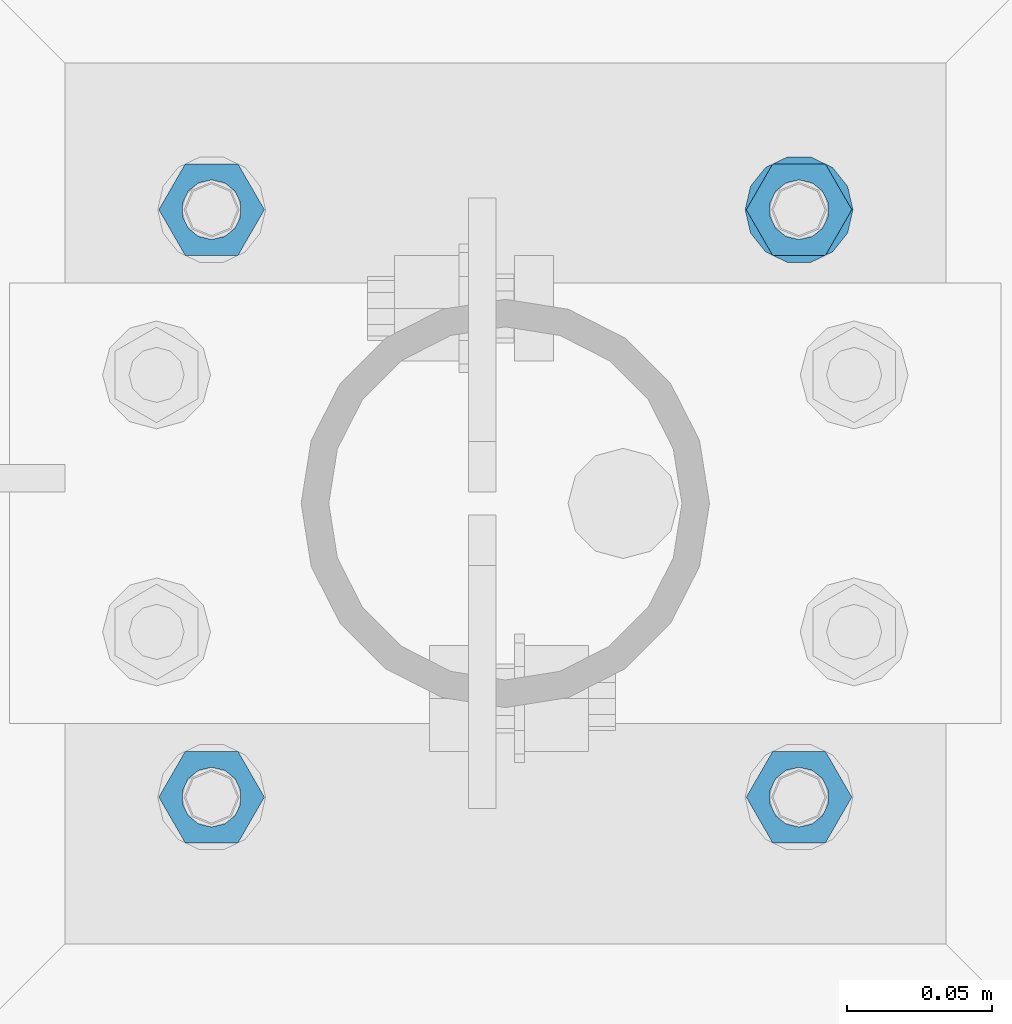
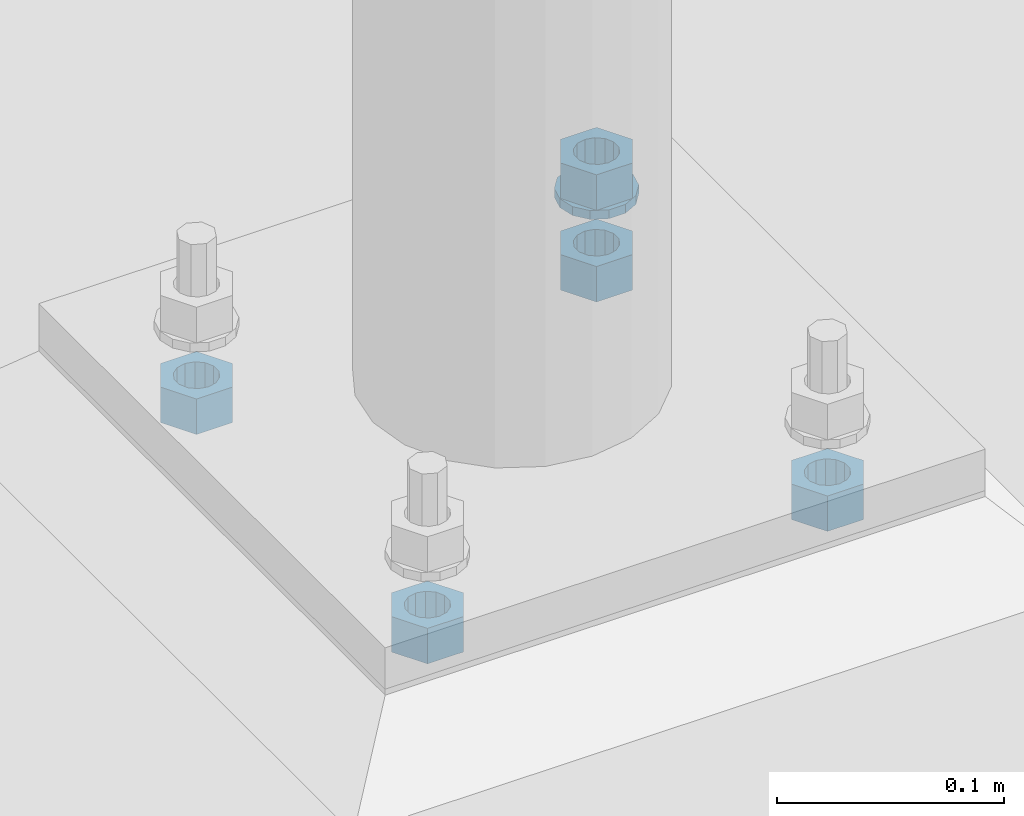
# One storey, part 564 of 975: 6 beams.
"""IFC2X3 building model written with IfcOpenShell, lengths in millimetres."""

from ifc_helpers import new_model, si_unit, frame, origin_with_axes, place, context, subcontext, project, spatial, faceted_brep, material, type_object, element, save


model = new_model("IFC2X3")

# Units and contexts
model_context = context("Model", 3, precision=1e-05, world=origin_with_axes())
body_context = subcontext(model_context, "Body", "Model", "MODEL_VIEW")
ifc_project = project(units=[si_unit("LENGTHUNIT", "METRE", prefix="MILLI"), si_unit("AREAUNIT", "SQUARE_METRE"), si_unit("VOLUMEUNIT", "CUBIC_METRE"), si_unit("MASSUNIT", "GRAM", prefix="KILO"), si_unit("TIMEUNIT", "SECOND"), si_unit("PLANEANGLEUNIT", "RADIAN"), si_unit("SOLIDANGLEUNIT", "STERADIAN"), si_unit("THERMODYNAMICTEMPERATUREUNIT", "DEGREE_CELSIUS"), si_unit("LUMINOUSINTENSITYUNIT", "LUMEN")], contexts=[model_context])

# Site, building, storey
site_placement = place(None, origin_with_axes())
site = spatial("IfcSite", under=ifc_project, at=site_placement, CompositionType="ELEMENT")
building_placement = place(site_placement, origin_with_axes())
building = spatial("IfcBuilding", under=site, at=building_placement, Name="Undefined", CompositionType="ELEMENT")
storey_placement = place(building_placement, origin_with_axes())
storey = spatial("IfcBuildingStorey", under=building, at=storey_placement, Name="Undefined", CompositionType="ELEMENT", Elevation=0.0)

# Beams
ifc_material = material(Name="STEEL/A36")
beam_type_1 = type_object("IfcBeamType", Name="3/4_WASHER", PredefinedType="NOTDEFINED")
beam_1_placement = place(storey_placement, frame((8331.19999847412, 13493.75, -236.537499999998), z_axis=(0.0, -1.0, 0.0), x_axis=(0.0, 0.0, -1.0)))
element("IfcBeam", 1, at=beam_1_placement, inside=storey, type_object=beam_type_1, material=ifc_material, Name="WASHER", ObjectType="3/4_WASHER", context=body_context, shape_type="Brep", body=[
    faceted_brep([(0.0, -18.6499996185303, 0.0), (0.0, -16.8030690426876, -8.09193156902904), (4.76250000000073, -16.8030690426876, -8.09193156902904), (4.76250000000073, -18.6499996185303, 0.0), (0.0, -11.6280845668225, -14.5811568497838), (4.76250000000073, -11.6280845668225, -14.5811568497838), (0.0, -4.15001533340001, -18.1824051902857), (4.76250000000073, -4.15001533340001, -18.1824051902857), (0.0, 4.15001533340001, -18.1824051902857), (4.76250000000073, 4.15001533340001, -18.1824051902857), (0.0, 11.6280845668234, -14.5811568497838), (4.76250000000073, 11.6280845668234, -14.5811568497838), (0.0, 16.8030690426876, -8.09193156902904), (4.76250000000073, 16.8030690426876, -8.09193156902904), (0.0, 18.6499996185303, 0.0), (4.76250000000073, 18.6499996185303, 0.0), (0.0, 16.8030690426876, 8.09193156902904), (4.76250000000073, 16.8030690426876, 8.09193156902904), (0.0, 11.6280845668225, 14.5811568497838), (4.76250000000073, 11.6280845668225, 14.5811568497838), (0.0, 4.15001533340001, 18.1824051902857), (4.76250000000073, 4.15001533340001, 18.1824051902857), (0.0, -4.15001533340001, 18.1824051902857), (4.76250000000073, -4.15001533340001, 18.1824051902857), (0.0, -11.6280845668234, 14.5811568497838), (4.76250000000073, -11.6280845668234, 14.5811568497838), (0.0, -16.8030690426876, 8.09193156902904), (4.76250000000073, -16.8030690426876, 8.09193156902904), (0.0, 0.0, 10.3199996948242), (0.0, 4.47768005528269, 9.29799844179911), (4.76250000000073, 4.47768005528269, 9.29799844179911), (4.76250000000073, 0.0, 10.3199996948242), (0.0, 8.06850066047446, 6.43441456490817), (4.76250000000073, 8.06850066047446, 6.43441456490817), (0.0, 10.0612557561917, 2.29641597052117), (4.76250000000073, 10.0612557561917, 2.29641597052117), (0.0, 10.0612557561917, -2.29641597052117), (4.76250000000073, 10.0612557561917, -2.29641597052117), (0.0, 8.06850066047446, -6.43441456490814), (4.76250000000073, 8.06850066047446, -6.43441456490814), (0.0, 4.47768005528269, -9.29799844179908), (4.76250000000073, 4.47768005528269, -9.29799844179908), (0.0, 0.0, -10.3199996948242), (4.76250000000073, 0.0, -10.3199996948242), (0.0, -4.47768005528269, -9.29799844179911), (4.76250000000073, -4.47768005528269, -9.29799844179911), (0.0, -8.06850066047446, -6.43441456490817), (4.76250000000073, -8.06850066047446, -6.43441456490817), (0.0, -10.0612557561917, -2.29641597052117), (4.76250000000073, -10.0612557561917, -2.29641597052117), (0.0, -10.0612557561917, 2.29641597052117), (4.76250000000073, -10.0612557561917, 2.29641597052117), (0.0, -8.06850066047446, 6.43441456490814), (4.76250000000073, -8.06850066047446, 6.43441456490814), (0.0, -4.47768005528269, 9.29799844179908), (4.76250000000073, -4.47768005528269, 9.29799844179908)], [[[0, 1, 2, 3]], [[1, 4, 5, 2]], [[4, 6, 7, 5]], [[6, 8, 9, 7]], [[8, 10, 11, 9]], [[10, 12, 13, 11]], [[12, 14, 15, 13]], [[14, 16, 17, 15]], [[16, 18, 19, 17]], [[18, 20, 21, 19]], [[20, 22, 23, 21]], [[22, 24, 25, 23]], [[24, 26, 27, 25]], [[26, 0, 3, 27]], [[28, 29, 30, 31]], [[29, 32, 33, 30]], [[32, 34, 35, 33]], [[34, 36, 37, 35]], [[36, 38, 39, 37]], [[38, 40, 41, 39]], [[40, 42, 43, 41]], [[42, 44, 45, 43]], [[44, 46, 47, 45]], [[46, 48, 49, 47]], [[48, 50, 51, 49]], [[50, 52, 53, 51]], [[52, 54, 55, 53]], [[54, 28, 31, 55]], [[5, 7, 9, 11, 13, 15, 17, 19, 21, 23, 25, 27, 3, 2], [33, 35, 37, 39, 41, 43, 45, 47, 49, 51, 53, 55, 31, 30]], [[26, 24, 22, 20, 18, 16, 14, 12, 10, 8, 6, 4, 1, 0], [54, 52, 50, 48, 46, 44, 42, 40, 38, 36, 34, 32, 29, 28]]]),
])
beam_type_2 = type_object("IfcBeamType", Name="3/4_HEAVY_HEX_NUT", PredefinedType="NOTDEFINED")
beam_2_placement = place(storey_placement, frame((8331.19999847412, 13493.75, -217.487499999999), z_axis=(0.0, -1.0, 0.0), x_axis=(0.0, 0.0, -1.0)))
element("IfcBeam", 2, at=beam_2_placement, inside=storey, type_object=beam_type_2, material=ifc_material, Name="NUT", ObjectType="3/4_HEAVY_HEX_NUT", context=body_context, shape_type="Brep", body=[
    faceted_brep([(0.0, -18.2600002288818, 0.0), (0.0, -9.13000011444092, -15.8100004196167), (19.0499999999993, -9.13000011444092, -15.8100004196167), (19.0499999999993, -18.2600002288818, 0.0), (0.0, 9.13000011444092, -15.8100004196167), (19.0499999999993, 9.13000011444092, -15.8100004196167), (0.0, 18.2600002288818, 0.0), (19.0499999999993, 18.2600002288818, 0.0), (0.0, 9.13000011444092, 15.8100004196167), (19.0499999999993, 9.13000011444092, 15.8100004196167), (0.0, -9.13000011444092, 15.8100004196167), (19.0499999999993, -9.13000011444092, 15.8100004196167), (0.0, 0.0, 10.3199996948242), (0.0, 4.47768005528269, 9.29799844179911), (19.0499999999993, 4.47768005528269, 9.29799844179911), (19.0499999999993, 0.0, 10.3199996948242), (0.0, 8.06850066047446, 6.43441456490817), (19.0499999999993, 8.06850066047446, 6.43441456490817), (0.0, 10.0612557561917, 2.29641597052117), (19.0499999999993, 10.0612557561917, 2.29641597052117), (0.0, 10.0612557561917, -2.29641597052117), (19.0499999999993, 10.0612557561917, -2.29641597052117), (0.0, 8.06850066047446, -6.43441456490814), (19.0499999999993, 8.06850066047446, -6.43441456490814), (0.0, 4.47768005528269, -9.29799844179908), (19.0499999999993, 4.47768005528269, -9.29799844179908), (0.0, 0.0, -10.3199996948242), (19.0499999999993, 0.0, -10.3199996948242), (0.0, -4.47768005528269, -9.29799844179911), (19.0499999999993, -4.47768005528269, -9.29799844179911), (0.0, -8.06850066047446, -6.43441456490817), (19.0499999999993, -8.06850066047446, -6.43441456490817), (0.0, -10.0612557561917, -2.29641597052117), (19.0499999999993, -10.0612557561917, -2.29641597052117), (0.0, -10.0612557561917, 2.29641597052117), (19.0499999999993, -10.0612557561917, 2.29641597052117), (0.0, -8.06850066047446, 6.43441456490814), (19.0499999999993, -8.06850066047446, 6.43441456490814), (0.0, -4.47768005528269, 9.29799844179908), (19.0499999999993, -4.47768005528269, 9.29799844179908)], [[[0, 1, 2, 3]], [[1, 4, 5, 2]], [[4, 6, 7, 5]], [[6, 8, 9, 7]], [[8, 10, 11, 9]], [[10, 0, 3, 11]], [[12, 13, 14, 15]], [[13, 16, 17, 14]], [[16, 18, 19, 17]], [[18, 20, 21, 19]], [[20, 22, 23, 21]], [[22, 24, 25, 23]], [[24, 26, 27, 25]], [[26, 28, 29, 27]], [[28, 30, 31, 29]], [[30, 32, 33, 31]], [[32, 34, 35, 33]], [[34, 36, 37, 35]], [[36, 38, 39, 37]], [[38, 12, 15, 39]], [[5, 7, 9, 11, 3, 2], [17, 19, 21, 23, 25, 27, 29, 31, 33, 35, 37, 39, 15, 14]], [[10, 8, 6, 4, 1, 0], [38, 36, 34, 32, 30, 28, 26, 24, 22, 20, 18, 16, 13, 12]]]),
])
beam_3_placement = place(storey_placement, frame((8128.00000152588, 13290.5500030518, -266.7), z_axis=(0.0, -1.0, 0.0), x_axis=(0.0, 0.0, -1.0)))
element("IfcBeam", 3, at=beam_3_placement, inside=storey, type_object=beam_type_2, material=ifc_material, Name="NUT", ObjectType="3/4_HEAVY_HEX_NUT", context=body_context, shape_type="Brep", body=[
    faceted_brep([(0.0, -18.2600002288818, 0.0), (0.0, -9.13000011444092, -15.8100004196167), (19.0499999999993, -9.13000011444092, -15.8100004196167), (19.0499999999993, -18.2600002288818, 0.0), (0.0, 9.13000011444092, -15.8100004196167), (19.0499999999993, 9.13000011444092, -15.8100004196167), (0.0, 18.2600002288818, 0.0), (19.0499999999993, 18.2600002288818, 0.0), (0.0, 9.13000011444092, 15.8100004196167), (19.0499999999993, 9.13000011444092, 15.8100004196167), (0.0, -9.13000011444092, 15.8100004196167), (19.0499999999993, -9.13000011444092, 15.8100004196167), (0.0, 0.0, 10.3199996948242), (0.0, 4.47768005528269, 9.29799844179911), (19.0499999999993, 4.47768005528269, 9.29799844179911), (19.0499999999993, 0.0, 10.3199996948242), (0.0, 8.06850066047446, 6.43441456490817), (19.0499999999993, 8.06850066047446, 6.43441456490817), (0.0, 10.0612557561917, 2.29641597052117), (19.0499999999993, 10.0612557561917, 2.29641597052117), (0.0, 10.0612557561917, -2.29641597052117), (19.0499999999993, 10.0612557561917, -2.29641597052117), (0.0, 8.06850066047446, -6.43441456490814), (19.0499999999993, 8.06850066047446, -6.43441456490814), (0.0, 4.47768005528269, -9.29799844179908), (19.0499999999993, 4.47768005528269, -9.29799844179908), (0.0, 0.0, -10.3199996948242), (19.0499999999993, 0.0, -10.3199996948242), (0.0, -4.47768005528269, -9.29799844179911), (19.0499999999993, -4.47768005528269, -9.29799844179911), (0.0, -8.06850066047446, -6.43441456490817), (19.0499999999993, -8.06850066047446, -6.43441456490817), (0.0, -10.0612557561917, -2.29641597052117), (19.0499999999993, -10.0612557561917, -2.29641597052117), (0.0, -10.0612557561917, 2.29641597052117), (19.0499999999993, -10.0612557561917, 2.29641597052117), (0.0, -8.06850066047446, 6.43441456490814), (19.0499999999993, -8.06850066047446, 6.43441456490814), (0.0, -4.47768005528269, 9.29799844179908), (19.0499999999993, -4.47768005528269, 9.29799844179908)], [[[0, 1, 2, 3]], [[1, 4, 5, 2]], [[4, 6, 7, 5]], [[6, 8, 9, 7]], [[8, 10, 11, 9]], [[10, 0, 3, 11]], [[12, 13, 14, 15]], [[13, 16, 17, 14]], [[16, 18, 19, 17]], [[18, 20, 21, 19]], [[20, 22, 23, 21]], [[22, 24, 25, 23]], [[24, 26, 27, 25]], [[26, 28, 29, 27]], [[28, 30, 31, 29]], [[30, 32, 33, 31]], [[32, 34, 35, 33]], [[34, 36, 37, 35]], [[36, 38, 39, 37]], [[38, 12, 15, 39]], [[5, 7, 9, 11, 3, 2], [17, 19, 21, 23, 25, 27, 29, 31, 33, 35, 37, 39, 15, 14]], [[10, 8, 6, 4, 1, 0], [38, 36, 34, 32, 30, 28, 26, 24, 22, 20, 18, 16, 13, 12]]]),
])
beam_4_placement = place(storey_placement, frame((8331.19999847412, 13290.5500030518, -266.7), z_axis=(0.0, -1.0, 0.0), x_axis=(0.0, 0.0, -1.0)))
element("IfcBeam", 4, at=beam_4_placement, inside=storey, type_object=beam_type_2, material=ifc_material, Name="NUT", ObjectType="3/4_HEAVY_HEX_NUT", context=body_context, shape_type="Brep", body=[
    faceted_brep([(0.0, -18.2600002288818, 0.0), (0.0, -9.13000011444092, -15.8100004196167), (19.0499999999993, -9.13000011444092, -15.8100004196167), (19.0499999999993, -18.2600002288818, 0.0), (0.0, 9.13000011444092, -15.8100004196167), (19.0499999999993, 9.13000011444092, -15.8100004196167), (0.0, 18.2600002288818, 0.0), (19.0499999999993, 18.2600002288818, 0.0), (0.0, 9.13000011444092, 15.8100004196167), (19.0499999999993, 9.13000011444092, 15.8100004196167), (0.0, -9.13000011444092, 15.8100004196167), (19.0499999999993, -9.13000011444092, 15.8100004196167), (0.0, 0.0, 10.3199996948242), (0.0, 4.47768005528269, 9.29799844179911), (19.0499999999993, 4.47768005528269, 9.29799844179911), (19.0499999999993, 0.0, 10.3199996948242), (0.0, 8.06850066047446, 6.43441456490817), (19.0499999999993, 8.06850066047446, 6.43441456490817), (0.0, 10.0612557561917, 2.29641597052117), (19.0499999999993, 10.0612557561917, 2.29641597052117), (0.0, 10.0612557561917, -2.29641597052117), (19.0499999999993, 10.0612557561917, -2.29641597052117), (0.0, 8.06850066047446, -6.43441456490814), (19.0499999999993, 8.06850066047446, -6.43441456490814), (0.0, 4.47768005528269, -9.29799844179908), (19.0499999999993, 4.47768005528269, -9.29799844179908), (0.0, 0.0, -10.3199996948242), (19.0499999999993, 0.0, -10.3199996948242), (0.0, -4.47768005528269, -9.29799844179911), (19.0499999999993, -4.47768005528269, -9.29799844179911), (0.0, -8.06850066047446, -6.43441456490817), (19.0499999999993, -8.06850066047446, -6.43441456490817), (0.0, -10.0612557561917, -2.29641597052117), (19.0499999999993, -10.0612557561917, -2.29641597052117), (0.0, -10.0612557561917, 2.29641597052117), (19.0499999999993, -10.0612557561917, 2.29641597052117), (0.0, -8.06850066047446, 6.43441456490814), (19.0499999999993, -8.06850066047446, 6.43441456490814), (0.0, -4.47768005528269, 9.29799844179908), (19.0499999999993, -4.47768005528269, 9.29799844179908)], [[[0, 1, 2, 3]], [[1, 4, 5, 2]], [[4, 6, 7, 5]], [[6, 8, 9, 7]], [[8, 10, 11, 9]], [[10, 0, 3, 11]], [[12, 13, 14, 15]], [[13, 16, 17, 14]], [[16, 18, 19, 17]], [[18, 20, 21, 19]], [[20, 22, 23, 21]], [[22, 24, 25, 23]], [[24, 26, 27, 25]], [[26, 28, 29, 27]], [[28, 30, 31, 29]], [[30, 32, 33, 31]], [[32, 34, 35, 33]], [[34, 36, 37, 35]], [[36, 38, 39, 37]], [[38, 12, 15, 39]], [[5, 7, 9, 11, 3, 2], [17, 19, 21, 23, 25, 27, 29, 31, 33, 35, 37, 39, 15, 14]], [[10, 8, 6, 4, 1, 0], [38, 36, 34, 32, 30, 28, 26, 24, 22, 20, 18, 16, 13, 12]]]),
])
beam_5_placement = place(storey_placement, frame((8128.00000152588, 13493.75, -266.7), z_axis=(0.0, -1.0, 0.0), x_axis=(0.0, 0.0, -1.0)))
element("IfcBeam", 5, at=beam_5_placement, inside=storey, type_object=beam_type_2, material=ifc_material, Name="NUT", ObjectType="3/4_HEAVY_HEX_NUT", context=body_context, shape_type="Brep", body=[
    faceted_brep([(0.0, -18.2600002288818, 0.0), (0.0, -9.13000011444092, -15.8100004196167), (19.0499999999993, -9.13000011444092, -15.8100004196167), (19.0499999999993, -18.2600002288818, 0.0), (0.0, 9.13000011444092, -15.8100004196167), (19.0499999999993, 9.13000011444092, -15.8100004196167), (0.0, 18.2600002288818, 0.0), (19.0499999999993, 18.2600002288818, 0.0), (0.0, 9.13000011444092, 15.8100004196167), (19.0499999999993, 9.13000011444092, 15.8100004196167), (0.0, -9.13000011444092, 15.8100004196167), (19.0499999999993, -9.13000011444092, 15.8100004196167), (0.0, 0.0, 10.3199996948242), (0.0, 4.47768005528269, 9.29799844179911), (19.0499999999993, 4.47768005528269, 9.29799844179911), (19.0499999999993, 0.0, 10.3199996948242), (0.0, 8.06850066047446, 6.43441456490817), (19.0499999999993, 8.06850066047446, 6.43441456490817), (0.0, 10.0612557561917, 2.29641597052117), (19.0499999999993, 10.0612557561917, 2.29641597052117), (0.0, 10.0612557561917, -2.29641597052117), (19.0499999999993, 10.0612557561917, -2.29641597052117), (0.0, 8.06850066047446, -6.43441456490814), (19.0499999999993, 8.06850066047446, -6.43441456490814), (0.0, 4.47768005528269, -9.29799844179908), (19.0499999999993, 4.47768005528269, -9.29799844179908), (0.0, 0.0, -10.3199996948242), (19.0499999999993, 0.0, -10.3199996948242), (0.0, -4.47768005528269, -9.29799844179911), (19.0499999999993, -4.47768005528269, -9.29799844179911), (0.0, -8.06850066047446, -6.43441456490817), (19.0499999999993, -8.06850066047446, -6.43441456490817), (0.0, -10.0612557561917, -2.29641597052117), (19.0499999999993, -10.0612557561917, -2.29641597052117), (0.0, -10.0612557561917, 2.29641597052117), (19.0499999999993, -10.0612557561917, 2.29641597052117), (0.0, -8.06850066047446, 6.43441456490814), (19.0499999999993, -8.06850066047446, 6.43441456490814), (0.0, -4.47768005528269, 9.29799844179908), (19.0499999999993, -4.47768005528269, 9.29799844179908)], [[[0, 1, 2, 3]], [[1, 4, 5, 2]], [[4, 6, 7, 5]], [[6, 8, 9, 7]], [[8, 10, 11, 9]], [[10, 0, 3, 11]], [[12, 13, 14, 15]], [[13, 16, 17, 14]], [[16, 18, 19, 17]], [[18, 20, 21, 19]], [[20, 22, 23, 21]], [[22, 24, 25, 23]], [[24, 26, 27, 25]], [[26, 28, 29, 27]], [[28, 30, 31, 29]], [[30, 32, 33, 31]], [[32, 34, 35, 33]], [[34, 36, 37, 35]], [[36, 38, 39, 37]], [[38, 12, 15, 39]], [[5, 7, 9, 11, 3, 2], [17, 19, 21, 23, 25, 27, 29, 31, 33, 35, 37, 39, 15, 14]], [[10, 8, 6, 4, 1, 0], [38, 36, 34, 32, 30, 28, 26, 24, 22, 20, 18, 16, 13, 12]]]),
])
beam_6_placement = place(storey_placement, frame((8331.19999847412, 13493.75, -266.7), z_axis=(0.0, -1.0, 0.0), x_axis=(0.0, 0.0, -1.0)))
element("IfcBeam", 6, at=beam_6_placement, inside=storey, type_object=beam_type_2, material=ifc_material, Name="NUT", ObjectType="3/4_HEAVY_HEX_NUT", context=body_context, shape_type="Brep", body=[
    faceted_brep([(0.0, -18.2600002288818, 0.0), (0.0, -9.13000011444092, -15.8100004196167), (19.0499999999993, -9.13000011444092, -15.8100004196167), (19.0499999999993, -18.2600002288818, 0.0), (0.0, 9.13000011444092, -15.8100004196167), (19.0499999999993, 9.13000011444092, -15.8100004196167), (0.0, 18.2600002288818, 0.0), (19.0499999999993, 18.2600002288818, 0.0), (0.0, 9.13000011444092, 15.8100004196167), (19.0499999999993, 9.13000011444092, 15.8100004196167), (0.0, -9.13000011444092, 15.8100004196167), (19.0499999999993, -9.13000011444092, 15.8100004196167), (0.0, 0.0, 10.3199996948242), (0.0, 4.47768005528269, 9.29799844179911), (19.0499999999993, 4.47768005528269, 9.29799844179911), (19.0499999999993, 0.0, 10.3199996948242), (0.0, 8.06850066047446, 6.43441456490817), (19.0499999999993, 8.06850066047446, 6.43441456490817), (0.0, 10.0612557561917, 2.29641597052117), (19.0499999999993, 10.0612557561917, 2.29641597052117), (0.0, 10.0612557561917, -2.29641597052117), (19.0499999999993, 10.0612557561917, -2.29641597052117), (0.0, 8.06850066047446, -6.43441456490814), (19.0499999999993, 8.06850066047446, -6.43441456490814), (0.0, 4.47768005528269, -9.29799844179908), (19.0499999999993, 4.47768005528269, -9.29799844179908), (0.0, 0.0, -10.3199996948242), (19.0499999999993, 0.0, -10.3199996948242), (0.0, -4.47768005528269, -9.29799844179911), (19.0499999999993, -4.47768005528269, -9.29799844179911), (0.0, -8.06850066047446, -6.43441456490817), (19.0499999999993, -8.06850066047446, -6.43441456490817), (0.0, -10.0612557561917, -2.29641597052117), (19.0499999999993, -10.0612557561917, -2.29641597052117), (0.0, -10.0612557561917, 2.29641597052117), (19.0499999999993, -10.0612557561917, 2.29641597052117), (0.0, -8.06850066047446, 6.43441456490814), (19.0499999999993, -8.06850066047446, 6.43441456490814), (0.0, -4.47768005528269, 9.29799844179908), (19.0499999999993, -4.47768005528269, 9.29799844179908)], [[[0, 1, 2, 3]], [[1, 4, 5, 2]], [[4, 6, 7, 5]], [[6, 8, 9, 7]], [[8, 10, 11, 9]], [[10, 0, 3, 11]], [[12, 13, 14, 15]], [[13, 16, 17, 14]], [[16, 18, 19, 17]], [[18, 20, 21, 19]], [[20, 22, 23, 21]], [[22, 24, 25, 23]], [[24, 26, 27, 25]], [[26, 28, 29, 27]], [[28, 30, 31, 29]], [[30, 32, 33, 31]], [[32, 34, 35, 33]], [[34, 36, 37, 35]], [[36, 38, 39, 37]], [[38, 12, 15, 39]], [[5, 7, 9, 11, 3, 2], [17, 19, 21, 23, 25, 27, 29, 31, 33, 35, 37, 39, 15, 14]], [[10, 8, 6, 4, 1, 0], [38, 36, 34, 32, 30, 28, 26, 24, 22, 20, 18, 16, 13, 12]]]),
])

save(model, "model.ifc")
